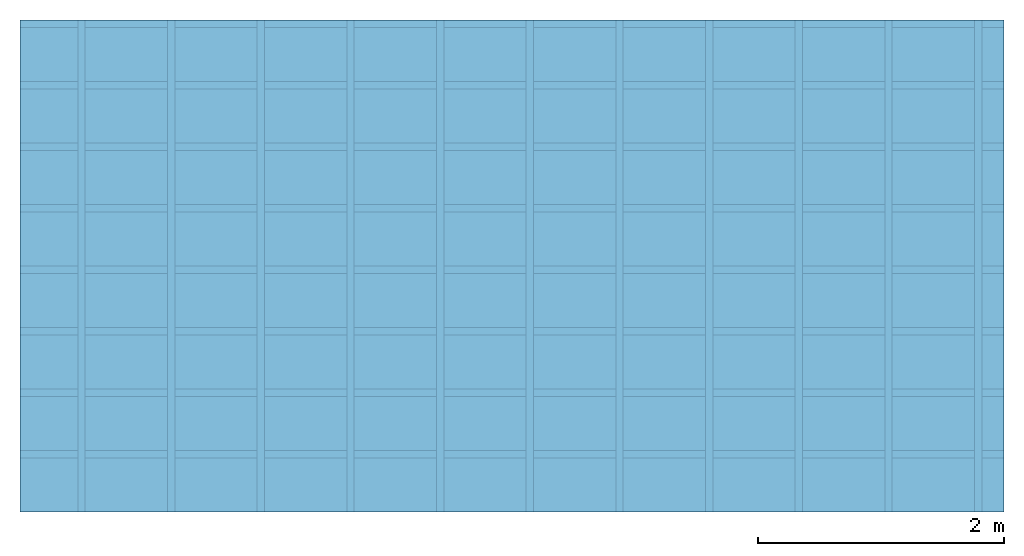
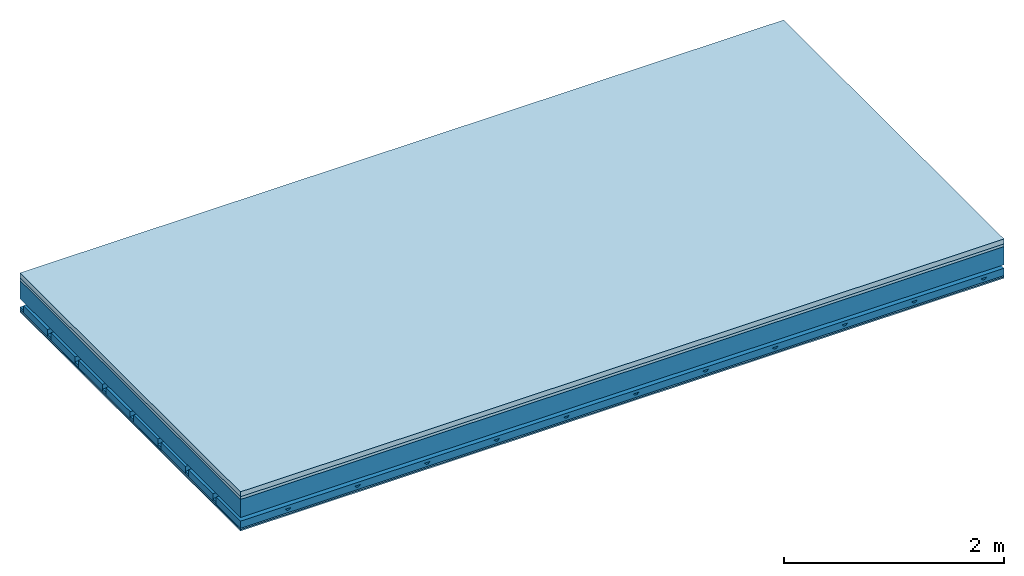
# One storey: 4 members, 4 plates, 1 element without a shape of its own.
"""IFC4 building model written with IfcOpenShell, lengths in metres."""

from ifc_helpers import new_model, si_unit, derived_unit, direction, frame, frame_2d, origin, origin_with_axes, place, context, project, spatial, polyline, rectangle, outline, extrude, material, layer, layer_set, type_object, element, aggregate, save


model = new_model("IFC4")

# Units and contexts
plan_context = context("Plan", 3, precision=1e-05, world=origin(), true_north=direction((0.0, 1.0)))
model_context = context("Model", 3, precision=1e-05, world=origin(), true_north=direction((0.0, 1.0)))
ifc_project = project(units=[si_unit("LENGTHUNIT", "METRE"), derived_unit("SOUNDPRESSUREUNIT", [(si_unit("PRESSUREUNIT", "PASCAL", prefix="MICRO"), 0)]), si_unit("ENERGYUNIT", "JOULE", prefix="MEGA"), si_unit("MASSUNIT", "GRAM", prefix="KILO"), derived_unit("THERMALTRANSMITTANCEUNIT", [(si_unit("POWERUNIT", "WATT"), 1), (si_unit("AREAUNIT", "SQUARE_METRE"), -1), (si_unit("THERMODYNAMICTEMPERATUREUNIT", "KELVIN"), -1)]), derived_unit("AREADENSITYUNIT", [(si_unit("MASSUNIT", "GRAM", prefix="KILO"), 1), (si_unit("AREAUNIT", "SQUARE_METRE"), -1)]), derived_unit("USERDEFINED", [(si_unit("ENERGYUNIT", "JOULE", prefix="MEGA"), 1), (si_unit("AREAUNIT", "SQUARE_METRE"), -1)])], contexts=[plan_context, model_context])

# Site, building, storey
site = spatial("IfcSite", under=ifc_project)
building_placement = place(None, origin())
building = spatial("IfcBuilding", under=site, at=building_placement)
storey_placement = place(building_placement, origin())
storey = spatial("IfcBuildingStorey", under=building, at=storey_placement)

# Slab, members, plates
ifc_material_1 = material(Category="04.005")
ifc_layer_1 = layer(ifc_material_1, 0.055, Name="On-material")
ifc_material_2 = material()
ifc_layer_2 = layer(ifc_material_2, 0.03, Name="Impact sound insulation")
ifc_layer_3 = layer(None, 0.2, Name="Supporting structure")
ifc_material_3 = material(Name="no composite action")
ifc_layer_4 = layer(ifc_material_3, 0.0, Name="Bond")
ifc_layer_5 = layer(None, 0.093, Name="Coupling")
ifc_layer_6 = layer(None, 0.027, Name="Battens / profiles")
ifc_material_4 = material(Category="03.007")
ifc_layer_7 = layer(ifc_material_4, 0.015, Name="Ceiling covering 1st layer")
ifc_layer_8 = layer(ifc_material_4, 0.015, Name="Ceiling covering layer 2")
ifc_material_5 = material(Name="Glued joints")
ifc_layer_9 = layer(ifc_material_5, 0.0, Name="Surface / treatment")
ifc_layer_set = layer_set([ifc_layer_1, ifc_layer_2, ifc_layer_3, ifc_layer_4, ifc_layer_5, ifc_layer_6, ifc_layer_7, ifc_layer_8, ifc_layer_9])
slab_type = type_object("IfcSlabType", Name="A0899", PredefinedType="NOTDEFINED", material=ifc_layer_set)
slab_placement = place(None, frame((0.0, 0.0, 0.0), z_axis=(0.0, 0.0, -1.0), x_axis=(1.0, 0.0, 0.0)))
slab = element("IfcSlab", 1, at=slab_placement, inside=storey, type_object=slab_type, material=ifc_layer_set, Name="Slab #1")
ifc_material_6 = material()
member_1_placement = place(slab_placement, origin())
member_1 = element("IfcMember", 2, at=member_1_placement, material=ifc_material_6, Name="Supporting structure", context=plan_context, shape_type="SweptSolid", body=[
    extrude(rectangle(XDim=1.0, YDim=0.2, at=frame_2d((0.5, 0.1), x_axis=(1.0, 0.0))), frame((0.0, 4.0, 0.085), z_axis=(0.0, -1.0, 0.0), x_axis=(1.0, 0.0, 0.0)), (0.0, 0.0, 1.0), 4.0),
    extrude(rectangle(XDim=1.0, YDim=0.2, at=frame_2d((0.5, 0.1), x_axis=(1.0, 0.0))), frame((1.0, 4.0, 0.085), z_axis=(0.0, -1.0, 0.0), x_axis=(1.0, 0.0, 0.0)), (0.0, 0.0, 1.0), 4.0),
    extrude(rectangle(XDim=1.0, YDim=0.2, at=frame_2d((0.5, 0.1), x_axis=(1.0, 0.0))), frame((2.0, 4.0, 0.085), z_axis=(0.0, -1.0, 0.0), x_axis=(1.0, 0.0, 0.0)), (0.0, 0.0, 1.0), 4.0),
    extrude(rectangle(XDim=1.0, YDim=0.2, at=frame_2d((0.5, 0.1), x_axis=(1.0, 0.0))), frame((3.0, 4.0, 0.085), z_axis=(0.0, -1.0, 0.0), x_axis=(1.0, 0.0, 0.0)), (0.0, 0.0, 1.0), 4.0),
    extrude(rectangle(XDim=1.0, YDim=0.2, at=frame_2d((0.5, 0.1), x_axis=(1.0, 0.0))), frame((4.0, 4.0, 0.085), z_axis=(0.0, -1.0, 0.0), x_axis=(1.0, 0.0, 0.0)), (0.0, 0.0, 1.0), 4.0),
    extrude(rectangle(XDim=1.0, YDim=0.2, at=frame_2d((0.5, 0.1), x_axis=(1.0, 0.0))), frame((5.0, 4.0, 0.085), z_axis=(0.0, -1.0, 0.0), x_axis=(1.0, 0.0, 0.0)), (0.0, 0.0, 1.0), 4.0),
    extrude(rectangle(XDim=1.0, YDim=0.2, at=frame_2d((0.5, 0.1), x_axis=(1.0, 0.0))), frame((6.0, 4.0, 0.085), z_axis=(0.0, -1.0, 0.0), x_axis=(1.0, 0.0, 0.0)), (0.0, 0.0, 1.0), 4.0),
    extrude(rectangle(XDim=1.0, YDim=0.2, at=frame_2d((0.5, 0.1), x_axis=(1.0, 0.0))), frame((7.0, 4.0, 0.085), z_axis=(0.0, -1.0, 0.0), x_axis=(1.0, 0.0, 0.0)), (0.0, 0.0, 1.0), 4.0),
])
ifc_material_7 = material()
member_2_placement = place(slab_placement, origin())
member_2 = element("IfcMember", 3, at=member_2_placement, material=ifc_material_7, Name="Coupling", context=plan_context, shape_type="SweptSolid", body=[
    extrude(outline(polyline([(0.0, 0.0), (0.06, 0.0), (0.04, 0.02), (0.02, 0.02), (0.0, 0.0)])), frame((0.47, 4.0, 0.358), z_axis=(0.0, -1.0, 0.0), x_axis=(1.0, 0.0, 0.0)), (0.0, 0.0, 1.0), 4.0),
    extrude(outline(polyline([(0.0, 0.0), (0.06, 0.0), (0.04, 0.02), (0.02, 0.02), (0.0, 0.0)])), frame((1.199, 4.0, 0.358), z_axis=(0.0, -1.0, 0.0), x_axis=(1.0, 0.0, 0.0)), (0.0, 0.0, 1.0), 4.0),
    extrude(outline(polyline([(0.0, 0.0), (0.06, 0.0), (0.04, 0.02), (0.02, 0.02), (0.0, 0.0)])), frame((1.928, 4.0, 0.358), z_axis=(0.0, -1.0, 0.0), x_axis=(1.0, 0.0, 0.0)), (0.0, 0.0, 1.0), 4.0),
    extrude(outline(polyline([(0.0, 0.0), (0.06, 0.0), (0.04, 0.02), (0.02, 0.02), (0.0, 0.0)])), frame((2.657, 4.0, 0.358), z_axis=(0.0, -1.0, 0.0), x_axis=(1.0, 0.0, 0.0)), (0.0, 0.0, 1.0), 4.0),
    extrude(outline(polyline([(0.0, 0.0), (0.06, 0.0), (0.04, 0.02), (0.02, 0.02), (0.0, 0.0)])), frame((3.386, 4.0, 0.358), z_axis=(0.0, -1.0, 0.0), x_axis=(1.0, 0.0, 0.0)), (0.0, 0.0, 1.0), 4.0),
    extrude(outline(polyline([(0.0, 0.0), (0.06, 0.0), (0.04, 0.02), (0.02, 0.02), (0.0, 0.0)])), frame((4.115, 4.0, 0.358), z_axis=(0.0, -1.0, 0.0), x_axis=(1.0, 0.0, 0.0)), (0.0, 0.0, 1.0), 4.0),
    extrude(outline(polyline([(0.0, 0.0), (0.06, 0.0), (0.04, 0.02), (0.02, 0.02), (0.0, 0.0)])), frame((4.844, 4.0, 0.358), z_axis=(0.0, -1.0, 0.0), x_axis=(1.0, 0.0, 0.0)), (0.0, 0.0, 1.0), 4.0),
    extrude(outline(polyline([(0.0, 0.0), (0.06, 0.0), (0.04, 0.02), (0.02, 0.02), (0.0, 0.0)])), frame((5.573, 4.0, 0.358), z_axis=(0.0, -1.0, 0.0), x_axis=(1.0, 0.0, 0.0)), (0.0, 0.0, 1.0), 4.0),
    extrude(outline(polyline([(0.0, 0.0), (0.06, 0.0), (0.04, 0.02), (0.02, 0.02), (0.0, 0.0)])), frame((6.302, 4.0, 0.358), z_axis=(0.0, -1.0, 0.0), x_axis=(1.0, 0.0, 0.0)), (0.0, 0.0, 1.0), 4.0),
    extrude(outline(polyline([(0.0, 0.0), (0.06, 0.0), (0.04, 0.02), (0.02, 0.02), (0.0, 0.0)])), frame((7.031, 4.0, 0.358), z_axis=(0.0, -1.0, 0.0), x_axis=(1.0, 0.0, 0.0)), (0.0, 0.0, 1.0), 4.0),
    extrude(outline(polyline([(0.0, 0.0), (0.06, 0.0), (0.04, 0.02), (0.02, 0.02), (0.0, 0.0)])), frame((7.76, 4.0, 0.358), z_axis=(0.0, -1.0, 0.0), x_axis=(1.0, 0.0, 0.0)), (0.0, 0.0, 1.0), 4.0),
])
ifc_material_8 = material()
member_3_placement = place(slab_placement, origin())
member_3 = element("IfcMember", 4, at=member_3_placement, material=ifc_material_8, Name="Battens / profiles", context=plan_context, shape_type="SweptSolid", body=[
    extrude(rectangle(XDim=0.06, YDim=0.027, at=frame_2d((0.03, 0.0135), x_axis=(1.0, 0.0))), frame((0.0, 0.0, 0.378), z_axis=(1.0, 0.0, 0.0), x_axis=(0.0, 1.0, 0.0)), (0.0, 0.0, 1.0), 8.0),
    extrude(rectangle(XDim=0.06, YDim=0.027, at=frame_2d((0.03, 0.0135), x_axis=(1.0, 0.0))), frame((0.0, 0.5, 0.378), z_axis=(1.0, 0.0, 0.0), x_axis=(0.0, 1.0, 0.0)), (0.0, 0.0, 1.0), 8.0),
    extrude(rectangle(XDim=0.06, YDim=0.027, at=frame_2d((0.03, 0.0135), x_axis=(1.0, 0.0))), frame((0.0, 1.0, 0.378), z_axis=(1.0, 0.0, 0.0), x_axis=(0.0, 1.0, 0.0)), (0.0, 0.0, 1.0), 8.0),
    extrude(rectangle(XDim=0.06, YDim=0.027, at=frame_2d((0.03, 0.0135), x_axis=(1.0, 0.0))), frame((0.0, 1.5, 0.378), z_axis=(1.0, 0.0, 0.0), x_axis=(0.0, 1.0, 0.0)), (0.0, 0.0, 1.0), 8.0),
    extrude(rectangle(XDim=0.06, YDim=0.027, at=frame_2d((0.03, 0.0135), x_axis=(1.0, 0.0))), frame((0.0, 2.0, 0.378), z_axis=(1.0, 0.0, 0.0), x_axis=(0.0, 1.0, 0.0)), (0.0, 0.0, 1.0), 8.0),
    extrude(rectangle(XDim=0.06, YDim=0.027, at=frame_2d((0.03, 0.0135), x_axis=(1.0, 0.0))), frame((0.0, 2.5, 0.378), z_axis=(1.0, 0.0, 0.0), x_axis=(0.0, 1.0, 0.0)), (0.0, 0.0, 1.0), 8.0),
    extrude(rectangle(XDim=0.06, YDim=0.027, at=frame_2d((0.03, 0.0135), x_axis=(1.0, 0.0))), frame((0.0, 3.0, 0.378), z_axis=(1.0, 0.0, 0.0), x_axis=(0.0, 1.0, 0.0)), (0.0, 0.0, 1.0), 8.0),
    extrude(rectangle(XDim=0.06, YDim=0.027, at=frame_2d((0.03, 0.0135), x_axis=(1.0, 0.0))), frame((0.0, 3.5, 0.378), z_axis=(1.0, 0.0, 0.0), x_axis=(0.0, 1.0, 0.0)), (0.0, 0.0, 1.0), 8.0),
])
ifc_material_9 = material()
member_4_placement = place(slab_placement, origin())
member_4 = element("IfcMember", 5, at=member_4_placement, material=ifc_material_9, Name="Cavity", context=plan_context, shape_type="SweptSolid", body=[
    extrude(rectangle(XDim=0.44, YDim=0.08, at=frame_2d((0.22, 0.04), x_axis=(1.0, 0.0))), frame((0.0, 0.06, 0.325), z_axis=(1.0, 0.0, 0.0), x_axis=(0.0, 1.0, 0.0)), (0.0, 0.0, 1.0), 8.0),
    extrude(rectangle(XDim=0.44, YDim=0.08, at=frame_2d((0.22, 0.04), x_axis=(1.0, 0.0))), frame((0.0, 0.56, 0.325), z_axis=(1.0, 0.0, 0.0), x_axis=(0.0, 1.0, 0.0)), (0.0, 0.0, 1.0), 8.0),
    extrude(rectangle(XDim=0.44, YDim=0.08, at=frame_2d((0.22, 0.04), x_axis=(1.0, 0.0))), frame((0.0, 1.06, 0.325), z_axis=(1.0, 0.0, 0.0), x_axis=(0.0, 1.0, 0.0)), (0.0, 0.0, 1.0), 8.0),
    extrude(rectangle(XDim=0.44, YDim=0.08, at=frame_2d((0.22, 0.04), x_axis=(1.0, 0.0))), frame((0.0, 1.56, 0.325), z_axis=(1.0, 0.0, 0.0), x_axis=(0.0, 1.0, 0.0)), (0.0, 0.0, 1.0), 8.0),
    extrude(rectangle(XDim=0.44, YDim=0.08, at=frame_2d((0.22, 0.04), x_axis=(1.0, 0.0))), frame((0.0, 2.06, 0.325), z_axis=(1.0, 0.0, 0.0), x_axis=(0.0, 1.0, 0.0)), (0.0, 0.0, 1.0), 8.0),
    extrude(rectangle(XDim=0.44, YDim=0.08, at=frame_2d((0.22, 0.04), x_axis=(1.0, 0.0))), frame((0.0, 2.56, 0.325), z_axis=(1.0, 0.0, 0.0), x_axis=(0.0, 1.0, 0.0)), (0.0, 0.0, 1.0), 8.0),
    extrude(rectangle(XDim=0.44, YDim=0.08, at=frame_2d((0.22, 0.04), x_axis=(1.0, 0.0))), frame((0.0, 3.06, 0.325), z_axis=(1.0, 0.0, 0.0), x_axis=(0.0, 1.0, 0.0)), (0.0, 0.0, 1.0), 8.0),
    extrude(rectangle(XDim=0.44, YDim=0.08, at=frame_2d((0.22, 0.04), x_axis=(1.0, 0.0))), frame((0.0, 3.56, 0.325), z_axis=(1.0, 0.0, 0.0), x_axis=(0.0, 1.0, 0.0)), (0.0, 0.0, 1.0), 8.0),
])
plate_1_placement = place(slab_placement, origin())
plate_1 = element("IfcPlate", 6, at=plate_1_placement, material=ifc_material_1, Name="On-material", context=plan_context, shape_type="SweptSolid", body=[
    extrude(rectangle(XDim=8.0, YDim=4.0, at=frame_2d((4.0, 2.0), x_axis=(1.0, 0.0))), origin_with_axes(), (0.0, 0.0, 1.0), 0.055),
])
plate_2_placement = place(slab_placement, origin())
plate_2 = element("IfcPlate", 7, at=plate_2_placement, material=ifc_material_2, Name="Impact sound insulation", context=plan_context, shape_type="SweptSolid", body=[
    extrude(rectangle(XDim=8.0, YDim=4.0, at=frame_2d((4.0, 2.0), x_axis=(1.0, 0.0))), frame((0.0, 0.0, 0.055), z_axis=(0.0, 0.0, 1.0), x_axis=(1.0, 0.0, 0.0)), (0.0, 0.0, 1.0), 0.03),
])
plate_3_placement = place(slab_placement, origin())
plate_3 = element("IfcPlate", 8, at=plate_3_placement, material=ifc_material_4, Name="Ceiling covering 1st layer", context=plan_context, shape_type="SweptSolid", body=[
    extrude(rectangle(XDim=8.0, YDim=4.0, at=frame_2d((4.0, 2.0), x_axis=(1.0, 0.0))), frame((0.0, 0.0, 0.405), z_axis=(0.0, 0.0, 1.0), x_axis=(1.0, 0.0, 0.0)), (0.0, 0.0, 1.0), 0.015),
])
plate_4_placement = place(slab_placement, origin())
plate_4 = element("IfcPlate", 9, at=plate_4_placement, material=ifc_material_4, Name="Ceiling covering layer 2", context=plan_context, shape_type="SweptSolid", body=[
    extrude(rectangle(XDim=8.0, YDim=4.0, at=frame_2d((4.0, 2.0), x_axis=(1.0, 0.0))), frame((0.0, 0.0, 0.42), z_axis=(0.0, 0.0, 1.0), x_axis=(1.0, 0.0, 0.0)), (0.0, 0.0, 1.0), 0.015),
])
aggregate(slab, [plate_1, plate_2, member_1, member_2, member_3, member_4, plate_3, plate_4])

save(model, "model.ifc")
